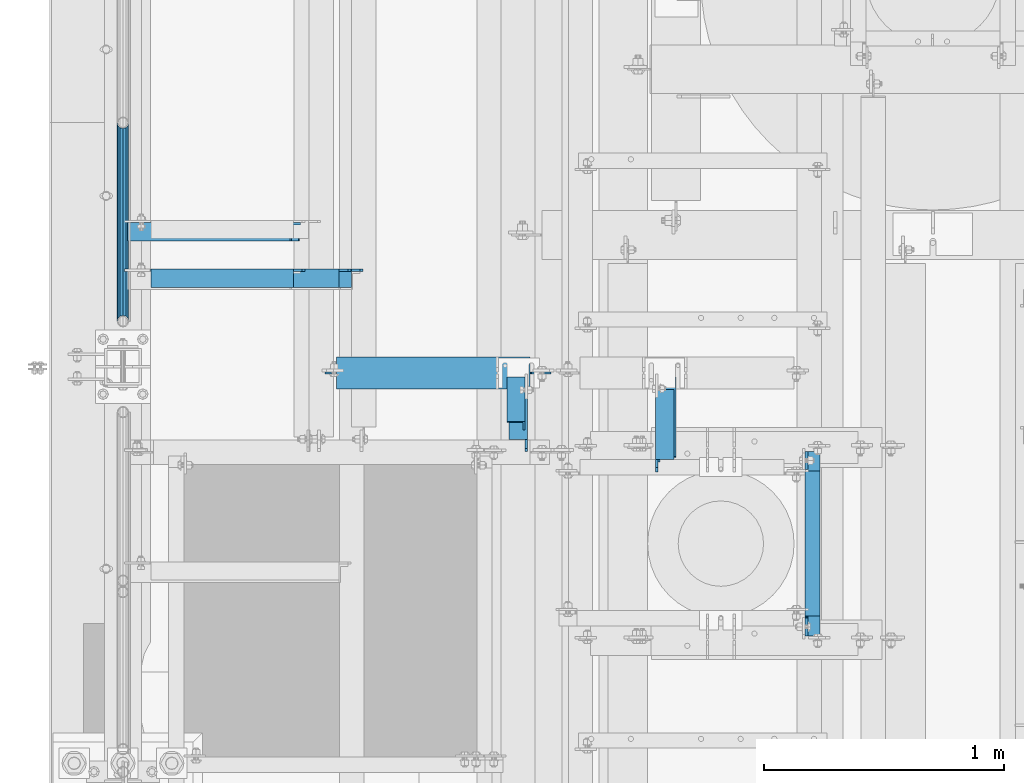
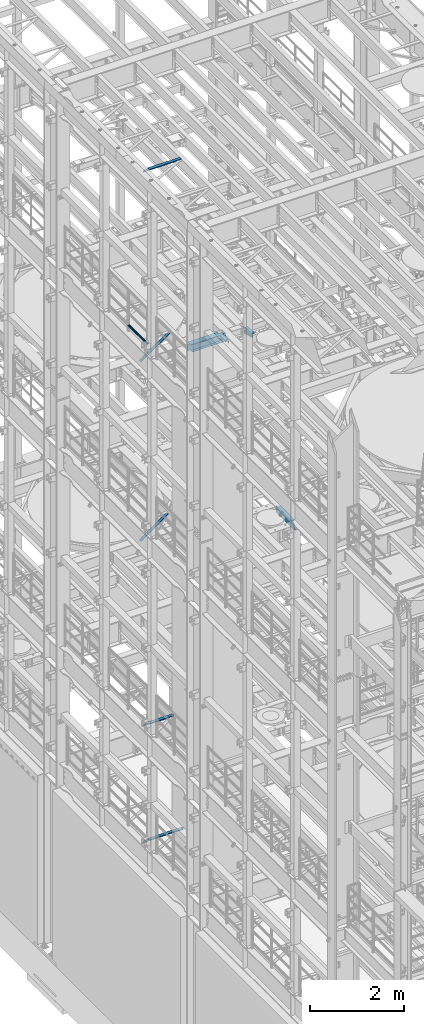
# One storey, part 1250 of 1876: 9 beams, 3 members, 12 elements without a shape of their own.
"""IFC2X3 building model written with IfcOpenShell, lengths in millimetres."""

from ifc_helpers import new_model, si_unit, frame, origin_with_axes, place, context, subcontext, project, spatial, faceted_brep, material, type_object, element, aggregate, save


model = new_model("IFC2X3")

# Units and contexts
model_context = context("Model", 3, precision=1e-05, world=origin_with_axes())
body_context = subcontext(model_context, "Body", "Model", "MODEL_VIEW")
ifc_project = project(units=[si_unit("LENGTHUNIT", "METRE", prefix="MILLI"), si_unit("AREAUNIT", "SQUARE_METRE"), si_unit("VOLUMEUNIT", "CUBIC_METRE"), si_unit("MASSUNIT", "GRAM", prefix="KILO"), si_unit("TIMEUNIT", "SECOND"), si_unit("PLANEANGLEUNIT", "RADIAN"), si_unit("SOLIDANGLEUNIT", "STERADIAN"), si_unit("THERMODYNAMICTEMPERATUREUNIT", "DEGREE_CELSIUS"), si_unit("LUMINOUSINTENSITYUNIT", "LUMEN")], contexts=[model_context])

# Site, building, storey
site_placement = place(None, origin_with_axes())
site = spatial("IfcSite", under=ifc_project, at=site_placement, CompositionType="ELEMENT")
building_placement = place(site_placement, origin_with_axes())
building = spatial("IfcBuilding", under=site, at=building_placement, Name="Undefined", CompositionType="ELEMENT")
storey_placement = place(building_placement, origin_with_axes())
storey = spatial("IfcBuildingStorey", under=building, at=storey_placement, Name="Undefined", CompositionType="ELEMENT", Elevation=0.0)

# Assembly, beam
assembly_1_placement = place(storey_placement, origin_with_axes())
assembly_1 = element("IfcElementAssembly", 1, at=assembly_1_placement, inside=storey, Name="RAIL", AssemblyPlace="NOTDEFINED", PredefinedType="RIGID_FRAME")
ifc_material_1 = material()
beam_type_1 = type_object("IfcBeamType", Name="PIPE1-1/2SCH40", PredefinedType="NOTDEFINED")
beam_1_placement = place(assembly_1_placement, frame((-1.81898940354586e-12, 4572.0, 18145.125), z_axis=(0.0, 0.0, 1.0), x_axis=(0.0, -1.0, 0.0)))
beam_1 = element("IfcBeam", 2, at=beam_1_placement, type_object=beam_type_1, material=ifc_material_1, Name="RAIL", ObjectType="PIPE1-1/2SCH40", context=body_context, shape_type="Brep", body=[
    faceted_brep([(805.872807006681, -12.0649999999996, 20.8971929933177), (805.872807006683, -12.0649999999996, 15.8661214311796), (805.379378568819, -10.2235000000001, 17.7076214311819), (802.640000000001, 0.0, 20.4470000000001), (802.640000000001, 0.0, 24.130000000001), (805.379378568819, 10.2235000000001, 17.7076214311819), (805.872807006683, 12.0649999999996, 15.8661214311796), (805.872807006681, 12.0649999999996, 20.8971929933177), (826.77, 24.1300000000001, 0.0), (814.705, 20.8971929933186, 12.0649999999987), (814.705, 20.8971929933186, -12.0649999999987), (811.515428437862, 17.7076214311801, 10.2235000000001), (814.254807006682, 20.4470000000001, 0.0), (811.515428437862, 17.7076214311801, -10.2235000000001), (805.872807006683, 12.0649999999996, -15.8661214311796), (805.872807006681, 12.0649999999996, -20.8971929933177), (805.379378568819, 10.2235000000001, -17.7076214311819), (802.640000000001, 0.0, -20.4470000000001), (802.640000000001, 0.0, -24.130000000001), (805.872807006683, -12.0649999999996, -15.8661214311796), (805.872807006681, -12.0649999999996, -20.8971929933177), (805.379378568819, -10.2235000000001, -17.7076214311819), (826.77, -24.1300000000001, 0.0), (814.705, -20.8971929933186, -12.0649999999987), (814.705, -20.8971929933186, 12.0649999999987), (811.515428437862, -17.7076214311801, -10.2235000000001), (814.254807006682, -20.4470000000001, 0.0), (811.515428437862, -17.7076214311801, 10.2235000000001), (12.0650000000064, -20.8971929933177, -12.0649999999987), (20.8971929933249, -12.0650000000005, -20.8971929933177), (0.0, 24.1299999999992, 0.0), (12.0650000000064, 20.8971929933177, -12.0649999999987), (12.0650000000064, 20.8971929933177, 12.0649999999987), (20.8971929933249, 12.0650000000005, 20.8971929933177), (24.1300000000064, 0.0, 24.130000000001), (20.8971929933249, 12.0650000000005, -20.8971929933177), (24.1300000000063, 0.0, -24.130000000001), (24.1300000000063, 0.0, -20.4470000000001), (20.8971929933249, -12.0650000000005, -15.8661214311796), (21.3906214311868, -10.2235000000001, -17.7076214311819), (21.3906214311868, 10.2235000000001, -17.7076214311819), (20.8971929933249, 12.0650000000005, -15.8661214311796), (15.2545715621445, 17.7076214311801, -10.2235000000001), (12.5151929933249, 20.4470000000001, 0.0), (15.2545715621445, 17.7076214311801, 10.2235000000001), (20.8971929933249, 12.0650000000005, 15.8661214311796), (21.3906214311868, 10.2235000000001, 17.7076214311819), (24.1300000000064, 0.0, 20.4470000000001), (21.3906214311868, -10.2235000000001, 17.7076214311819), (20.8971929933249, -12.0650000000005, 15.8661214311796), (20.8971929933249, -12.0650000000005, 20.8971929933177), (12.0650000000064, -20.8971929933177, 12.0649999999987), (0.0, -24.1299999999992, 0.0), (15.2545715621445, -17.7076214311801, 10.2235000000001), (12.5151929933249, -20.4470000000001, 0.0), (15.2545715621445, -17.7076214311801, -10.2235000000001)], [[[0, 1, 2, 3, 4]], [[4, 3, 5, 6, 7]], [[8, 9, 10]], [[7, 6, 11, 12, 13, 14, 15, 10, 9]], [[16, 17, 18, 15, 14]], [[19, 20, 18, 17, 21]], [[22, 23, 24]], [[24, 23, 20, 19, 25, 26, 27, 1, 0]], [[28, 29, 20, 23]], [[30, 31, 32]], [[33, 34, 4, 7]], [[32, 33, 7, 9]], [[30, 32, 9, 8]], [[31, 30, 8, 10]], [[35, 31, 10, 15]], [[36, 35, 15, 18]], [[29, 36, 18, 20]], [[37, 36, 29, 38, 39]], [[40, 41, 35, 36, 37]], [[32, 31, 35, 41, 42, 43, 44, 45, 33]], [[33, 45, 46, 47, 34]], [[34, 47, 48, 49, 50]], [[34, 50, 0, 4]], [[50, 51, 24, 0]], [[51, 52, 22, 24]], [[52, 28, 23, 22]], [[51, 28, 52]], [[50, 49, 53, 54, 55, 38, 29, 28, 51]], [[55, 54, 26, 25]], [[21, 39, 38, 55, 25, 19]], [[37, 39, 21, 17]], [[40, 37, 17, 16]], [[42, 41, 40, 16, 14, 13]], [[43, 42, 13, 12]], [[44, 43, 12, 11]], [[5, 46, 45, 44, 11, 6]], [[47, 46, 5, 3]], [[48, 47, 3, 2]], [[53, 49, 48, 2, 1, 27]], [[54, 53, 27, 26]]]),
])
aggregate(assembly_1, [beam_1])

# Assembly, member
assembly_2_placement = place(storey_placement, origin_with_axes())
assembly_2 = element("IfcElementAssembly", 3, at=assembly_2_placement, inside=storey, AssemblyPlace="NOTDEFINED", PredefinedType="RIGID_FRAME")
ifc_material_2 = material(Name="STEEL/A36")
member_type = type_object("IfcMemberType", Name="L3X3X3/8", PredefinedType="NOTDEFINED")
member_1_placement = place(assembly_2_placement, frame((1636.32505689916, 3529.79856245166, 17814.9249999999), z_axis=(-1.0, 0.0, 0.0), x_axis=(4.99999977048871e-08, -0.890526982409433, 0.454930427209202)))
member_1 = element("IfcMember", 4, at=member_1_placement, type_object=member_type, material=ifc_material_2, ObjectType="L3X3X3/8", context=body_context, shape_type="Brep", body=[
    faceted_brep([(37.2901101871148, 38.1000000000095, -38.0999999999983), (37.2901101771431, 38.0999999999258, 38.1000000000017), (246.457293823823, 38.0999999996566, 38.1000000000172), (246.457293833795, 38.0999999997366, -38.0999999999829), (37.2901101771522, 28.5749999999243, 38.1000000000017), (246.457293823833, 28.5749999996515, 38.1000000000172), (37.290110185877, 28.5749999999935, -28.5749999999982), (246.457293832559, 28.5749999997242, -28.5749999999828), (37.2901101859452, -38.1000000000313, -28.5749999999969), (246.457293832626, -38.1000000003041, -28.5749999999814), (37.2901101871912, -38.1000000000204, -38.099999999997), (246.457293833872, -38.1000000002932, -38.0999999999815)], [[[0, 1, 2, 3]], [[1, 4, 5, 2]], [[4, 6, 7, 5]], [[6, 8, 9, 7]], [[8, 10, 11, 9]], [[10, 0, 3, 11]], [[5, 7, 9, 11, 3, 2]], [[10, 8, 6, 4, 1, 0]]]),
])
aggregate(assembly_2, [member_1])

assembly_3_placement = place(storey_placement, origin_with_axes())
assembly_3 = element("IfcElementAssembly", 5, at=assembly_3_placement, inside=storey, Name="BRACE", AssemblyPlace="NOTDEFINED", PredefinedType="RIGID_FRAME")
member_2_placement = place(assembly_3_placement, frame((22.1939716660531, 4117.975, 12757.9316674292), z_axis=(0.0, -1.0, 0.0), x_axis=(0.812817140855119, 0.0, 0.582518922896166)))
member_2 = element("IfcMember", 6, at=member_2_placement, type_object=member_type, material=ifc_material_2, Name="BRACE", ObjectType="L3X3X3/8", context=body_context, shape_type="Brep", body=[
    faceted_brep([(855.723229872639, 28.5750000000744, 38.0999999999999), (855.723229872639, 28.5750000000744, -28.5749999999998), (855.723229872628, -38.0999999999331, -28.5749999999998), (855.723229872628, -38.0999999999331, -38.0999999999999), (855.72322987264, 38.1000000000749, -38.0999999999999), (855.72322987264, 38.1000000000749, 38.0999999999999), (24.4135476554093, 28.5750000000053, 38.0999999999999), (24.4135476554093, 28.5750000000053, -28.5749999999998), (24.4135476553975, -38.1000000000031, -28.5749999999998), (24.4135476553975, -38.1000000000031, -38.0999999999999), (24.4135476554111, 38.1000000000058, -38.0999999999999), (24.4135476554111, 38.1000000000058, 38.0999999999999)], [[[0, 1, 2, 3, 4, 5]], [[6, 7, 1, 0]], [[7, 8, 2, 1]], [[8, 9, 3, 2]], [[9, 10, 4, 3]], [[10, 11, 5, 4]], [[11, 6, 0, 5]], [[9, 8, 7, 6, 11, 10]]]),
])
aggregate(assembly_3, [member_2])

assembly_4_placement = place(storey_placement, origin_with_axes())
assembly_4 = element("IfcElementAssembly", 7, at=assembly_4_placement, inside=storey, AssemblyPlace="NOTDEFINED", PredefinedType="RIGID_FRAME")
member_3_placement = place(assembly_4_placement, frame((21.6869001657126, 4117.975, 17424.2669187563), z_axis=(0.0, -1.0, 0.0), x_axis=(0.822192192147785, 0.0, 0.569209978102299)))
member_3 = element("IfcMember", 8, at=member_3_placement, type_object=member_type, material=ifc_material_2, ObjectType="L3X3X3/8", context=body_context, shape_type="Brep", body=[
    faceted_brep([(24.1351720308776, 38.0999999999403, -38.1000000000004), (24.1351720308776, 38.0999999999403, 38.0999999999999), (887.866654075793, 38.0999999989017, 38.0999999999999), (887.866654075793, 38.0999999989017, -38.1000000000004), (24.135172030894, 28.5749999999462, 38.0999999999999), (887.866654075808, 28.5749999989075, 38.0999999999999), (24.135172030894, 28.5749999999462, -28.5749999999998), (887.866654075808, 28.5749999989075, -28.5749999999998), (24.1351720310122, -38.0999999999985, -28.5749999999998), (887.86665407593, -38.1000000010354, -28.5749999999998), (24.1351720310122, -38.0999999999985, -38.1000000000004), (887.86665407593, -38.1000000010354, -38.1000000000004)], [[[0, 1, 2, 3]], [[1, 4, 5, 2]], [[4, 6, 7, 5]], [[6, 8, 9, 7]], [[8, 10, 11, 9]], [[10, 0, 3, 11]], [[5, 7, 9, 11, 3, 2]], [[10, 8, 6, 4, 1, 0]]]),
])
aggregate(assembly_4, [member_3])

# Assembly, beam
assembly_5_placement = place(storey_placement, origin_with_axes())
assembly_5 = element("IfcElementAssembly", 9, at=assembly_5_placement, inside=storey, Name="ANGLE", AssemblyPlace="NOTDEFINED", PredefinedType="RIGID_FRAME")
beam_type_2 = type_object("IfcBeamType", Name="L3X3X3/8", PredefinedType="NOTDEFINED")
beam_2_placement = place(assembly_5_placement, frame((1645.85007534541, 3200.40000211734, 17945.1), z_axis=(0.0, 0.0, -1.0), x_axis=(0.0, 1.0, 0.0)))
beam_2 = element("IfcBeam", 10, at=beam_2_placement, type_object=beam_type_2, material=ifc_material_2, Name="ANGLE", ObjectType="L3X3X3/8", context=body_context, shape_type="Brep", body=[
    faceted_brep([(261.13656597509, -38.1000000000233, -28.5750000000007), (261.136565975052, -38.1000000000233, -38.0999999999985), (261.136563308052, 38.0999999999765, -38.0999999999985), (261.136563308055, 38.0999999999765, -28.5750001907327), (261.136563641435, 28.5749999999766, -28.5750000000007), (313.523561484631, 38.0999999999719, -28.5750001907327), (313.52356181801, 28.5749999999721, -28.5750000000007), (326.223561293896, 38.0999999999706, -15.8750003814675), (326.223561627275, 28.5749999999709, -15.8750003814675), (326.223561293896, 38.0999999999706, -3.17500152587672), (326.223561627275, 28.5749999999709, -3.17500152587672), (326.223561422883, 38.0999999999706, 38.0999999999985), (326.223561956286, 28.5749999999709, 38.0999999999985), (3.17499385834481, 28.5749999999998, -15.8750003814748), (15.8749936676099, 28.5749999999989, -28.5750000000007), (52.3869956588824, 28.5749999999955, -28.5750000000007), (3.1749962690983, 28.575, 38.0999999999985), (3.17499385834481, 28.5749999999998, -3.175001525884), (52.3869975924608, -38.1000000000047, -28.57500019074), (52.3869975924608, -38.1000000000047, -38.0999999999985), (52.3869953826566, 38.0999999999954, -38.0999999999985), (52.3869953826566, 38.0999999999954, -28.57500019074), (15.8749933913846, 38.0999999999985, -28.57500019074), (3.17499358211944, 38.0999999999997, -15.8750003814748), (3.17499358211944, 38.0999999999997, -3.175001525884), (3.17499573569603, 38.0999999999999, 38.0999999999985)], [[[0, 1, 2, 3, 4]], [[4, 3, 5, 6]], [[6, 5, 7, 8]], [[8, 7, 9, 10]], [[9, 11, 12, 10]], [[13, 14, 15, 4, 6, 8, 10, 12, 16, 17]], [[0, 4, 15, 18]], [[1, 0, 18, 19]], [[2, 1, 19, 20]], [[18, 15, 21, 20, 19]], [[14, 22, 21, 15]], [[13, 23, 22, 14]], [[17, 24, 23, 13]], [[11, 9, 7, 5, 3, 2, 20, 21, 22, 23, 24, 25]], [[12, 11, 25, 16]], [[24, 17, 16, 25]]]),
])
aggregate(assembly_5, [beam_2])

assembly_6_placement = place(storey_placement, origin_with_axes())
assembly_6 = element("IfcElementAssembly", 11, at=assembly_6_placement, inside=storey, AssemblyPlace="NOTDEFINED", PredefinedType="RIGID_FRAME")
beam_3_placement = place(assembly_6_placement, frame((2264.97480935019, 3094.48437897731, 17946.6232861287), z_axis=(1.0, 0.0, 0.0), x_axis=(1.41999999489063e-07, 0.960018736693322, -0.279935751910572)))
beam_3 = element("IfcBeam", 12, at=beam_3_placement, type_object=beam_type_2, material=ifc_material_2, ObjectType="L3X3X3/8", context=body_context, shape_type="Brep", body=[
    faceted_brep([(79.393217357278, 38.099999999904, -38.100000000004), (79.3932173509211, 38.0999999999985, 38.0999999999967), (425.797504471688, 38.0999999999549, 38.0999999999494), (425.797504478045, 38.0999999998603, -38.1000000000513), (79.3932173509188, 28.575000000008, 38.0999999999954), (425.797504471686, 28.5749999999643, 38.0999999999476), (79.3932173564804, 28.5749999999243, -28.5750000000057), (425.797504477248, 28.5749999998807, -28.575000000053), (79.3932173564635, -38.1000000000095, -28.575000000018), (425.79750447723, -38.1000000000531, -28.5750000000653), (79.393217357258, -38.100000000024, -38.1000000000172), (425.797504478025, -38.1000000000677, -38.1000000000645)], [[[0, 1, 2, 3]], [[1, 4, 5, 2]], [[4, 6, 7, 5]], [[6, 8, 9, 7]], [[8, 10, 11, 9]], [[10, 0, 3, 11]], [[5, 7, 9, 11, 3, 2]], [[10, 8, 6, 4, 1, 0]]]),
])
aggregate(assembly_6, [beam_3])

assembly_7_placement = place(storey_placement, origin_with_axes())
assembly_7 = element("IfcElementAssembly", 13, at=assembly_7_placement, inside=storey, Name="ANGLE", AssemblyPlace="NOTDEFINED", PredefinedType="RIGID_FRAME")
beam_4_placement = place(assembly_7_placement, frame((2255.44981093073, 3105.14993112121, 17945.1), z_axis=(1.0, 0.0, 0.0), x_axis=(0.0, 1.0, 0.0)))
beam_4 = element("IfcBeam", 14, at=beam_4_placement, type_object=beam_type_2, material=ifc_material_2, Name="ANGLE", ObjectType="L3X3X3/8", context=body_context, shape_type="Brep", body=[
    faceted_brep([(356.386630808539, 28.5750000000007, -28.5750000000712), (356.3866420766, 28.5750000000007, 38.099999999929), (65.0870741885001, 28.5750001907327, 38.0999999999876), (65.087062587038, 28.5750000000007, -28.5750000000126), (356.3866420766, 38.0999999999985, 38.099999999929), (65.0870741885001, 38.0999999999985, 38.0999999999876), (31.750262965455, 28.5750000000007, -28.5750000000062), (31.7502613081033, 28.5750001907327, -38.1000000000063), (12.7002620710418, 9.52500095367213, -38.1000000000022), (12.7002637283936, 9.52500095367213, -28.5750000000021), (65.0870609296862, 28.5750001907327, -38.1000000000131), (65.0870609296862, 38.0999999999985, -38.1000000000131), (356.386629198817, 38.0999999999985, -38.1000000000718), (356.386629198817, 28.5750001907254, -38.1000000000718), (408.773628985116, 28.5750000000007, -28.5750000000821), (408.773627375393, 28.5750001907254, -38.1000000000822), (421.473628794382, 15.8750003814603, -28.5750000000849), (421.473627184659, 15.8750003814603, -38.1000000000849), (421.473628794382, 3.17500152586945, -28.5750000000849), (421.473627184659, 3.17500152586945, -38.1000000000849), (421.47363032353, -38.0999999999985, -28.5750000000844), (421.47362891383, -38.0999999999985, -38.1000000000845), (12.700266020031, -38.0999999999985, -28.5750000000021), (12.700264610331, -38.0999999999985, -38.1000000000026), (12.7002620710418, 3.17500152587672, -38.1000000000022), (12.7002637283936, 3.17500152587672, -28.5750000000021)], [[[0, 1, 2, 3]], [[1, 4, 5, 2]], [[6, 7, 8, 9]], [[3, 10, 7, 6]], [[2, 5, 11, 10, 3]], [[4, 12, 11, 5]], [[1, 0, 13, 12, 4]], [[14, 15, 13, 0]], [[16, 17, 15, 14]], [[18, 19, 17, 16]], [[19, 18, 20, 21]], [[21, 20, 22, 23]], [[8, 7, 10, 11, 12, 13, 15, 17, 19, 21, 23, 24]], [[9, 8, 24, 25]], [[20, 18, 16, 14, 0, 3, 6, 9, 25, 22]], [[24, 23, 22, 25]]]),
])
aggregate(assembly_7, [beam_4])

assembly_8_placement = place(storey_placement, origin_with_axes())
assembly_8 = element("IfcElementAssembly", 15, at=assembly_8_placement, inside=storey, Name="ANGLE", AssemblyPlace="NOTDEFINED", PredefinedType="RIGID_FRAME")
beam_5_placement = place(assembly_8_placement, frame((4.51516825708356e-09, 3924.3, 22517.1), z_axis=(0.0, -1.0, 0.0), x_axis=(1.0, 0.0, 0.0)))
beam_5 = element("IfcBeam", 16, at=beam_5_placement, type_object=beam_type_2, material=ifc_material_2, Name="ANGLE", ObjectType="L3X3X3/8", context=body_context, shape_type="Brep", body=[
    faceted_brep([(115.886999817316, 28.5750000000007, 38.0999999999999), (115.886999817316, 38.0999999999985, 38.0999999999999), (115.886998826692, 38.0999999999985, -38.0999999999999), (115.88699882669, 12.699999237062, -38.0999999999999), (115.886998950515, 12.699999237062, -28.5749999999998), (115.88699895052, 28.5750000000007, -28.5749999999998), (38.8937432114558, 12.699999237062, -38.0999999999999), (38.8937433352807, 12.699999237062, -28.5749999999998), (7.14374321145577, -19.050000762938, -38.0999999999999), (7.14374333528067, -19.050000762938, -28.5749999999998), (7.1437499954859, -38.0999999999985, -38.0999999999999), (7.1437499954859, -38.0999999999985, -28.5749999999998), (949.325002419604, 15.8750003814712, -28.5749999999998), (936.625002610339, 28.5750000000007, -28.5749999999998), (900.113000619098, 28.5750000000007, -28.5749999999998), (949.324999995485, -38.0999999999985, -28.5749999999998), (949.325002419604, 3.17500152588036, -28.5749999999998), (900.11300241932, 28.5750000000007, 38.0999999999999), (900.1130024193, 38.0999999999985, 38.0999999999999), (900.113000361957, 38.0999999999985, -38.0999999999999), (900.113000361924, 28.5750001907363, -38.0999999999999), (936.625002353164, 28.5750001907363, -38.0999999999999), (949.325002162429, 15.8750003814712, -38.0999999999999), (949.325002162429, 3.17500152588036, -38.0999999999999), (949.324999995485, -38.0999999999985, -38.0999999999999)], [[[0, 1, 2, 3, 4, 5]], [[4, 3, 6, 7]], [[7, 6, 8, 9]], [[8, 10, 11, 9]], [[12, 13, 14, 5, 4, 7, 9, 11, 15, 16]], [[0, 5, 14, 17]], [[1, 0, 17, 18]], [[2, 1, 18, 19]], [[17, 14, 20, 19, 18]], [[13, 21, 20, 14]], [[12, 22, 21, 13]], [[16, 23, 22, 12]], [[10, 8, 6, 3, 2, 19, 20, 21, 22, 23, 24]], [[11, 10, 24, 15]], [[23, 16, 15, 24]]]),
])
aggregate(assembly_8, [beam_5])

assembly_9_placement = place(storey_placement, origin_with_axes())
assembly_9 = element("IfcElementAssembly", 17, at=assembly_9_placement, inside=storey, Name="ANGLE", AssemblyPlace="NOTDEFINED", PredefinedType="RIGID_FRAME")
beam_6_placement = place(assembly_9_placement, frame((0.0, 3924.3, 8115.3), z_axis=(0.0, -1.0, 0.0), x_axis=(1.0, 0.0, 0.0)))
beam_6 = element("IfcBeam", 18, at=beam_6_placement, type_object=beam_type_2, material=ifc_material_2, Name="ANGLE", ObjectType="L3X3X3/8", context=body_context, shape_type="Brep", body=[
    faceted_brep([(115.886999817316, 28.5750000000007, 38.0999999999999), (115.886999817316, 38.0999999999985, 38.0999999999999), (115.886998826692, 38.0999999999985, -38.0999999999999), (115.88699882669, 12.699999237062, -38.0999999999999), (115.886998950515, 12.699999237062, -28.5749999999998), (115.88699895052, 28.5750000000007, -28.5749999999998), (38.8937432114558, 12.699999237062, -38.0999999999999), (38.8937433352807, 12.699999237062, -28.5749999999998), (7.14374321145577, -19.050000762938, -38.0999999999999), (7.14374333528067, -19.050000762938, -28.5749999999998), (7.1437499954859, -38.0999999999985, -38.0999999999999), (7.1437499954859, -38.0999999999985, -28.5749999999998), (758.825002424117, 15.8750003814712, -28.5749999999998), (746.125002614852, 28.5749999999998, -28.5749999999998), (709.61300062358, 28.5749999999998, -28.5749999999998), (758.824999999999, -38.1000000000004, -28.5749999999998), (758.825002424117, 3.17500152588036, -28.5749999999998), (709.613002423808, 28.5749999999998, 38.1000000000004), (709.613002423808, 38.1000000000004, 38.1000000000004), (709.613000366395, 38.1000000000004, -38.1000000000004), (709.613000366404, 28.5750001907363, -38.1000000000004), (746.125002357676, 28.5750001907363, -38.1000000000004), (758.825002166941, 15.8750003814712, -38.1000000000004), (758.825002166941, 3.17500152588036, -38.1000000000004), (758.824999999999, -38.1000000000004, -38.1000000000004)], [[[0, 1, 2, 3, 4, 5]], [[4, 3, 6, 7]], [[7, 6, 8, 9]], [[8, 10, 11, 9]], [[12, 13, 14, 5, 4, 7, 9, 11, 15, 16]], [[0, 5, 14, 17]], [[1, 0, 17, 18]], [[2, 1, 18, 19]], [[17, 14, 20, 19, 18]], [[13, 21, 20, 14]], [[12, 22, 21, 13]], [[16, 23, 22, 12]], [[10, 8, 6, 3, 2, 19, 20, 21, 22, 23, 24]], [[11, 10, 24, 15]], [[23, 16, 15, 24]]]),
])
aggregate(assembly_9, [beam_6])

assembly_10_placement = place(storey_placement, origin_with_axes())
assembly_10 = element("IfcElementAssembly", 19, at=assembly_10_placement, inside=storey, Name="ANGLE", AssemblyPlace="NOTDEFINED", PredefinedType="RIGID_FRAME")
beam_7_placement = place(assembly_10_placement, frame((0.0, 3924.3, 5092.7), z_axis=(0.0, -1.0, 0.0), x_axis=(1.0, 0.0, 0.0)))
beam_7 = element("IfcBeam", 20, at=beam_7_placement, type_object=beam_type_2, material=ifc_material_2, Name="ANGLE", ObjectType="L3X3X3/8", context=body_context, shape_type="Brep", body=[
    faceted_brep([(115.886999817316, 28.5750000000007, 38.0999999999999), (115.886999817316, 38.0999999999985, 38.0999999999999), (115.886998826692, 38.0999999999985, -38.0999999999999), (115.88699882669, 12.699999237062, -38.0999999999999), (115.886998950515, 12.699999237062, -28.5749999999998), (115.88699895052, 28.5750000000007, -28.5749999999998), (38.8937432114558, 12.699999237062, -38.0999999999999), (38.8937433352807, 12.699999237062, -28.5749999999998), (7.14374321145577, -19.050000762938, -38.0999999999999), (7.14374333528067, -19.050000762938, -28.5749999999998), (7.1437499954859, -38.0999999999985, -38.0999999999999), (7.1437499954859, -38.0999999999985, -28.5749999999998), (1000.12500242412, 15.8750003814712, -28.5749999999998), (987.425002614851, 28.5749999999998, -28.5749999999998), (950.913000303442, 28.5749999999998, -28.5749999999998), (1000.12500001551, -38.1000000000004, -28.5749999999998), (1000.12500242412, 3.17500152588036, -28.5749999999998), (950.913001170238, 28.5749999999998, 38.0999999999999), (950.913001170238, 38.1000000000004, 38.0999999999999), (950.913000179614, 38.1000000000004, -38.0999999999999), (950.913000366403, 28.5750001907363, -38.0999999999999), (987.425002357675, 28.5750001907363, -38.0999999999999), (1000.12500216694, 15.8750003814712, -38.0999999999999), (1000.12500216694, 3.17500152588036, -38.0999999999999), (1000.12500001551, -38.1000000000004, -38.0999999999999)], [[[0, 1, 2, 3, 4, 5]], [[4, 3, 6, 7]], [[7, 6, 8, 9]], [[8, 10, 11, 9]], [[12, 13, 14, 5, 4, 7, 9, 11, 15, 16]], [[0, 5, 14, 17]], [[1, 0, 17, 18]], [[2, 1, 18, 19]], [[17, 14, 20, 19, 18]], [[13, 21, 20, 14]], [[12, 22, 21, 13]], [[16, 23, 22, 12]], [[10, 8, 6, 3, 2, 19, 20, 21, 22, 23, 24]], [[11, 10, 24, 15]], [[23, 16, 15, 24]]]),
])
aggregate(assembly_10, [beam_7])

assembly_11_placement = place(storey_placement, origin_with_axes())
assembly_11 = element("IfcElementAssembly", 21, at=assembly_11_placement, inside=storey, Name="BEAM", AssemblyPlace="NOTDEFINED", PredefinedType="RIGID_FRAME")
ifc_material_3 = material(Name="STEEL/A992")
beam_type_3 = type_object("IfcBeamType", Name="W8X18", PredefinedType="NOTDEFINED")
beam_8_placement = place(assembly_11_placement, frame((825.499999999999, 3529.79856567383, 17880.0125), z_axis=(0.0, 0.0, 1.0), x_axis=(1.0, 0.0, 0.0)))
beam_8 = element("IfcBeam", 22, at=beam_8_placement, type_object=beam_type_3, material=ifc_material_3, Name="BEAM", ObjectType="W8X18", context=body_context, shape_type="Brep", body=[
    faceted_brep([(15.875, -3.17500000000018, -77.7874999999949), (15.875, 3.17500000000018, -77.7874999999949), (95.2500001907356, 3.17500000000018, -77.7874999999949), (95.2500001907356, -3.17500000000018, -77.7874999999949), (100.110079708781, 3.17500000000018, -78.7542299225825), (100.110079708781, -3.17500000000018, -78.7542299225825), (104.230256176935, 3.17500000000018, -81.50724382306), (104.230256176935, -3.17500000000018, -81.50724382306), (106.983270077413, 3.17500000000018, -85.6274202912136), (106.983270077413, -3.17500000000018, -85.6274202912136), (107.950000000001, -3.17500000000018, -90.48749980926), (107.950000000001, 3.17500000000018, -90.48749980926), (107.950000000001, 3.17500000000018, -95.25), (107.950000000001, 66.6750000000002, -95.25), (107.950000000001, 66.6750000000002, -103.1875), (107.950000000001, -66.6750000000002, -103.1875), (107.950000000001, -66.6750000000002, -95.25), (107.950000000001, -3.17500000000018, -95.25), (868.3625, -66.6750000000002, -103.1875), (868.3625, 66.6750000000002, -103.1875), (868.3625, 66.6750000000002, -96.8374998092659), (868.3625, -66.6750000000002, -96.8374998092659), (868.3625, 66.6750000000002, 95.25), (868.3625, 3.17500000000018, 95.25), (63.1842266547242, 3.17500000000018, 95.25), (63.1842266547242, 66.6750000000002, 95.25), (50.8000001907358, -3.17500000000018, 84.1375000000044), (50.8000001907358, 3.17500000000018, 84.1375000000044), (15.875, 3.17500000000018, 84.1375000000044), (15.875, -3.17500000000018, 84.1375000000044), (55.6600797087813, -3.17500000000018, 85.1042299225919), (55.6600797087813, 3.17500000000018, 85.1042299225919), (59.7802561769349, -3.17500000000018, 87.8572438230694), (59.7802561769349, 3.17500000000018, 87.8572438230694), (62.5332700774129, -3.17500000000018, 91.9774202912231), (62.5332700774129, 3.17500000000018, 91.9774202912231), (868.3625, -66.6750000000002, 103.1875), (868.3625, 66.6750000000002, 103.1875), (63.5000000000009, 66.6750000000002, 103.1875), (63.5000000000009, -66.6750000000002, 103.1875), (63.1842266547242, -66.6750000000002, 95.25), (868.3625, -66.6750000000002, 95.25), (63.5000000000009, -66.6750000000002, 96.8374998092695), (868.3625, -3.17500000000018, 95.25), (63.1842266547242, -3.17500000000018, 95.25), (63.5000000000009, 66.6750000000002, 96.8374998092695), (868.3625, -3.17500000000018, 84.1374998092651), (868.3625, 3.17500000000018, 84.1374998092651), (869.329229922588, -3.17500000000018, 79.2774202912187), (869.329229922588, 3.17500000000018, 79.2774202912187), (872.082243823066, -3.17500000000018, 75.1572438230651), (872.082243823066, 3.17500000000018, 75.1572438230651), (876.20242029122, -3.17500000000018, 72.4042299225875), (876.20242029122, 3.17500000000018, 72.4042299225875), (881.062499809265, -3.17500000000018, 71.4375), (881.062499809265, 3.17500000000018, 71.4375), (957.2625, -3.17500000000018, 71.4375), (957.2625, 3.17500000000018, 71.4375), (957.2625, -3.17500000000018, -84.1375000000007), (957.2625, 3.17500000000018, -84.1375000000007), (881.062499809266, -3.17500000000018, -84.1375000000007), (881.062499809266, 3.17500000000018, -84.1375000000007), (876.20242029122, -3.17500000000018, -85.1042299225883), (876.20242029122, 3.17500000000018, -85.1042299225883), (872.082243823066, -3.17500000000018, -87.8572438230658), (872.082243823066, 3.17500000000018, -87.8572438230658), (869.329229922588, -3.17500000000018, -91.9774202912195), (869.329229922588, 3.17500000000018, -91.9774202912195), (868.678273345276, -3.17500000000018, -95.25), (868.678273345276, -66.6750000000002, -95.25), (868.678273345276, 66.6750000000002, -95.25), (868.678273345276, 3.17500000000018, -95.25)], [[[0, 1, 2, 3]], [[3, 2, 4, 5]], [[5, 4, 6, 7]], [[7, 6, 8, 9]], [[10, 11, 12, 13, 14, 15, 16, 17]], [[9, 8, 11, 10]], [[18, 19, 20, 21]], [[22, 23, 24, 25]], [[26, 27, 28, 29]], [[30, 31, 27, 26]], [[32, 33, 31, 30]], [[34, 35, 33, 32]], [[36, 37, 38, 39]], [[40, 41, 36, 39, 42]], [[43, 41, 40, 44]], [[42, 45, 25, 24, 35, 34, 44, 40]], [[39, 38, 45, 42]], [[37, 22, 25, 45, 38]], [[36, 41, 43, 46, 47, 23, 22, 37]], [[48, 49, 47, 46]], [[50, 51, 49, 48]], [[52, 53, 51, 50]], [[54, 55, 53, 52]], [[56, 57, 55, 54]], [[57, 56, 58, 59]], [[58, 60, 61, 59]], [[62, 63, 61, 60]], [[64, 65, 63, 62]], [[66, 67, 65, 64]], [[68, 69, 21, 20, 70, 71, 67, 66]], [[69, 68, 17, 16]], [[18, 21, 69, 16, 15]], [[19, 18, 15, 14]], [[70, 20, 19, 14, 13]], [[71, 70, 13, 12]], [[6, 4, 2, 1, 28, 27, 31, 33, 35, 24, 23, 47, 49, 51, 53, 55, 57, 59, 61, 63, 65, 67, 71, 12, 11, 8]], [[29, 28, 1, 0]], [[68, 66, 64, 62, 60, 58, 56, 54, 52, 50, 48, 46, 43, 44, 34, 32, 30, 26, 29, 0, 3, 5, 7, 9, 10, 17]]]),
])
aggregate(assembly_11, [beam_8])

assembly_12_placement = place(storey_placement, origin_with_axes())
assembly_12 = element("IfcElementAssembly", 23, at=assembly_12_placement, inside=storey, Name="BEAM", AssemblyPlace="NOTDEFINED", PredefinedType="RIGID_FRAME")
beam_type_4 = type_object("IfcBeamType", Name="C8X18.75", PredefinedType="NOTDEFINED")
beam_9_placement = place(assembly_12_placement, frame((2870.2, 2419.35, 13208.0), z_axis=(0.0, 0.0, 1.0), x_axis=(0.0, 1.0, 0.0)))
beam_9 = element("IfcBeam", 24, at=beam_9_placement, type_object=beam_type_4, material=ifc_material_2, Name="BEAM", ObjectType="C8X18.75", context=body_context, shape_type="Brep", body=[
    faceted_brep([(85.7250001907341, 19.0500000000002, 76.2000000000007), (85.7250001907341, 31.75, 76.2000000000007), (15.875, 31.75, 76.2000000000007), (15.875, 19.0500000000002, 76.2000000000007), (90.5850797087796, 19.0500000000002, 77.1667299225883), (90.5850797087796, 31.75, 77.1667299225883), (94.7052561769333, 19.0500000000002, 79.9197438230658), (94.7052561769333, 31.75, 79.9197438230658), (97.4582700774113, 19.0500000000002, 84.0399202912195), (97.4582700774113, 31.75, 84.0399202912195), (98.4249999999993, 19.0500000000002, 88.9012700000003), (98.4249999999993, 31.75, 88.8999998092659), (98.4249999999993, -31.75, 101.6), (98.4249999999993, 31.75, 101.6), (98.4249999999993, -31.75, 97.3645500000002), (15.875, 19.0499999999993, -88.9012699999985), (15.875, -31.75, -97.3645499999984), (784.225, -31.75, -97.3645500000002), (784.225, 19.0500000000002, -88.9012700000003), (15.875, -31.75, -101.599999999999), (784.225, -31.75, -101.6), (15.875, 31.75, -101.599999999999), (784.225, 31.75, -101.6), (784.225, 31.75, 76.2000000000007), (784.225, 19.0500000000002, 76.2000000000007), (714.374999809265, 31.75, 76.2000000000007), (714.374999809265, 19.0500000000002, 76.2000000000007), (709.51492029122, 31.75, 77.1667299225883), (709.51492029122, 19.0500000000002, 77.1667299225883), (705.394743823066, 31.75, 79.9197438230658), (705.394743823066, 19.0500000000002, 79.9197438230658), (702.641729922588, 31.75, 84.0399202912195), (702.641729922588, 19.0500000000002, 84.0399202912195), (701.675, 31.75, 88.8999998092659), (701.675, 19.0500000000002, 88.9012700000003), (701.675, -31.75, 101.6), (701.675, -31.75, 97.3645500000002), (701.675, 31.75, 101.6)], [[[0, 1, 2, 3]], [[4, 5, 1, 0]], [[6, 7, 5, 4]], [[8, 9, 7, 6]], [[10, 11, 9, 8]], [[12, 13, 11, 10, 14]], [[15, 16, 17, 18]], [[16, 19, 20, 17]], [[19, 21, 22, 20]], [[18, 17, 20, 22, 23, 24]], [[24, 23, 25, 26]], [[26, 25, 27, 28]], [[28, 27, 29, 30]], [[30, 29, 31, 32]], [[32, 31, 33, 34]], [[35, 36, 34, 33, 37]], [[36, 35, 12, 14]], [[34, 36, 14, 10]], [[6, 4, 0, 3, 15, 18, 24, 26, 28, 30, 32, 34, 10, 8]], [[21, 19, 16, 15, 3, 2]], [[37, 33, 31, 29, 27, 25, 23, 22, 21, 2, 1, 5, 7, 9, 11, 13]], [[35, 37, 13, 12]]]),
])
aggregate(assembly_12, [beam_9])

save(model, "model.ifc")
